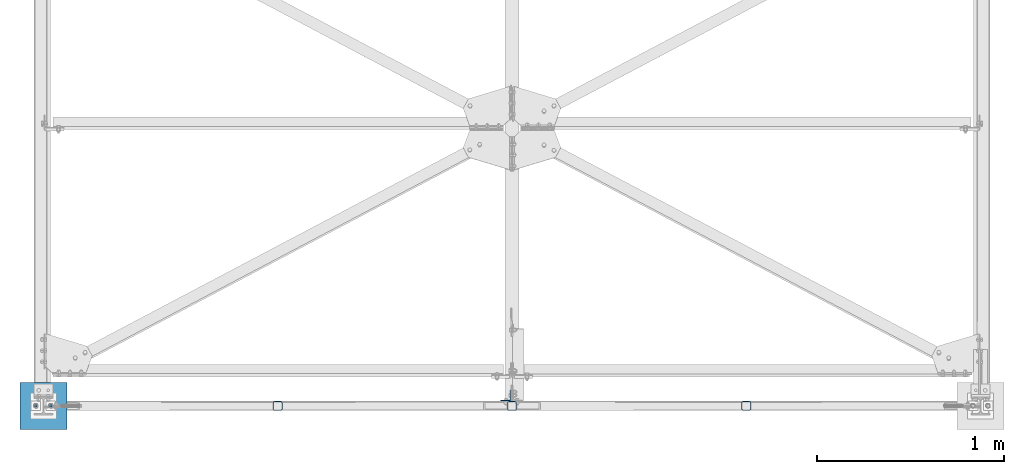
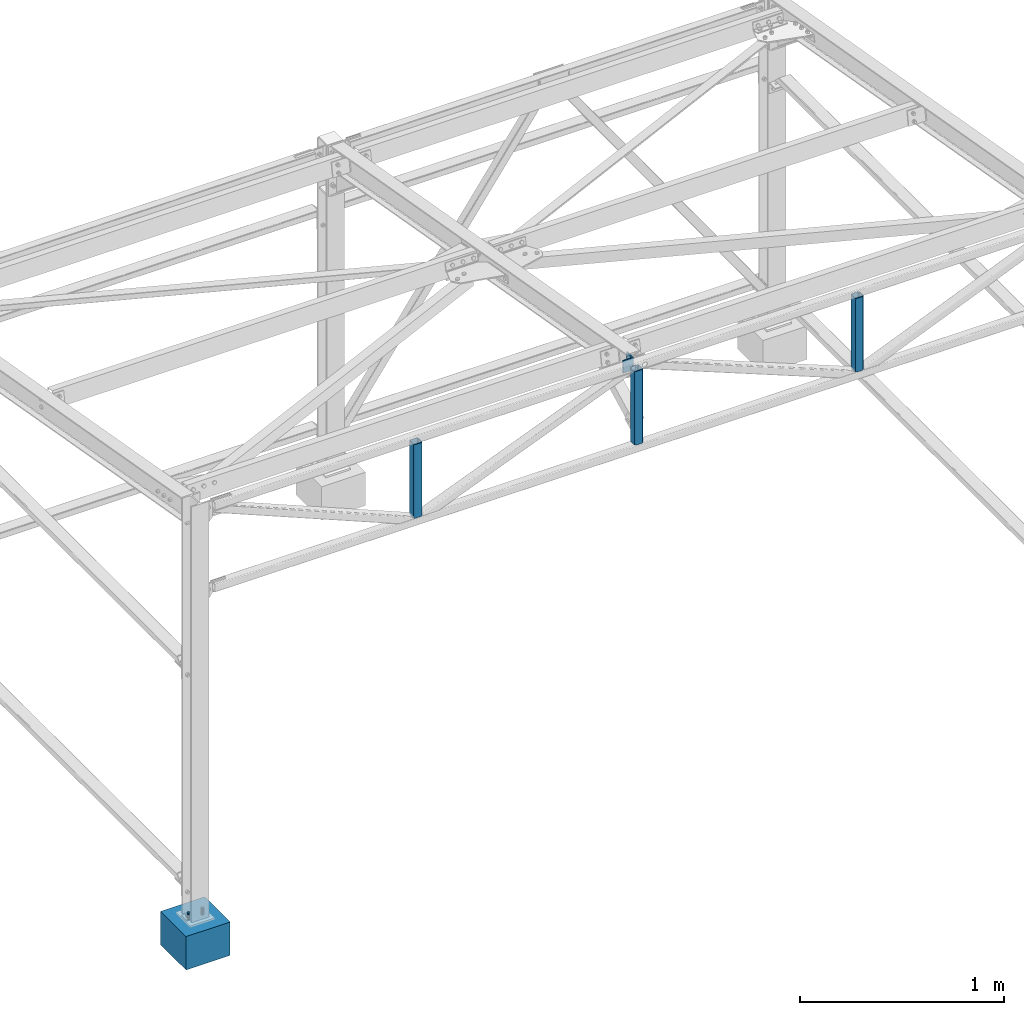
# One storey, part 2 of 28: 7 columns, 5 elements without a shape of their own.
"""IFC2X3 building model written with IfcOpenShell, lengths in millimetres."""

from ifc_helpers import new_model, si_unit, frame, origin_with_axes, origin_2d_with_axis, place, context, subcontext, project, spatial, rectangle, hollow_rectangle, circle, l_section, extrude, clip, halfspace, material, type_object, element, aggregate, save


model = new_model("IFC2X3")

# Units and contexts
model_context = context("Model", 3, precision=1e-05, world=origin_with_axes())
body_context = subcontext(model_context, "Body", "Model", "MODEL_VIEW")
ifc_project = project(units=[si_unit("LENGTHUNIT", "METRE", prefix="MILLI"), si_unit("AREAUNIT", "SQUARE_METRE"), si_unit("VOLUMEUNIT", "CUBIC_METRE"), si_unit("MASSUNIT", "GRAM", prefix="KILO"), si_unit("TIMEUNIT", "SECOND"), si_unit("PLANEANGLEUNIT", "RADIAN"), si_unit("SOLIDANGLEUNIT", "STERADIAN"), si_unit("THERMODYNAMICTEMPERATUREUNIT", "DEGREE_CELSIUS"), si_unit("LUMINOUSINTENSITYUNIT", "LUMEN")], contexts=[model_context])

# Site, building, storey
site_placement = place(None, origin_with_axes())
site = spatial("IfcSite", under=ifc_project, at=site_placement, CompositionType="ELEMENT")
building_placement = place(site_placement, origin_with_axes())
building = spatial("IfcBuilding", under=site, at=building_placement, Name="Undefined", CompositionType="ELEMENT")
storey_placement = place(building_placement, origin_with_axes())
storey = spatial("IfcBuildingStorey", under=building, at=storey_placement, Name="Undefined", CompositionType="ELEMENT", Elevation=0.0)

# Assembly, column
assembly_1_placement = place(storey_placement, origin_with_axes())
assembly_1 = element("IfcElementAssembly", 1, at=assembly_1_placement, inside=storey, Name="FA", AssemblyPlace="NOTDEFINED", PredefinedType="NOTDEFINED")
ifc_material_1 = material(Name="STEEL/S235JR")
column_type_1 = type_object("IfcColumnType", PredefinedType="NOTDEFINED")
column_1_placement = place(assembly_1_placement, frame((2467.65, 55.0, 2585.99989966715), z_axis=(0.0, 0.0, 1.0), x_axis=(0.0, 1.0, 0.0)))
column_1 = element("IfcColumn", 2, at=column_1_placement, type_object=column_type_1, material=ifc_material_1, Name="FA", context=body_context, shape_type="SweptSolid", body=[
    extrude(l_section(Depth=60.0, Width=60.0, Thickness=6.0, FilletRadius=9.0, at=origin_2d_with_axis()), frame((0.0, 0.0, 75.0), z_axis=(0.0, 0.0, -1.0), x_axis=(0.0, 1.0, 0.0)), (0.0, 0.0, 1.0), 75.0),
])
aggregate(assembly_1, [column_1])

assembly_2_placement = place(storey_placement, origin_with_axes())
assembly_2 = element("IfcElementAssembly", 3, at=assembly_2_placement, inside=storey, AssemblyPlace="NOTDEFINED", PredefinedType="NOTDEFINED")
column_type_2 = type_object("IfcColumnType", Name="D14", PredefinedType="NOTDEFINED")
column_2_placement = place(assembly_2_placement, frame((-40.0000000003815, 9.91491333479644e-10, 239.999895901477), z_axis=(0.0, 0.0, -1.0), x_axis=(0.0, -1.0, 0.0)))
column_2 = element("IfcColumn", 4, at=column_2_placement, type_object=column_type_2, material=ifc_material_1, context=body_context, shape_type="SweptSolid", body=[
    extrude(circle(Radius=7.0, at=origin_2d_with_axis()), frame((0.0, 0.0, 200.0), z_axis=(0.0, 0.0, -1.0), x_axis=(0.0, 1.0, 0.0)), (0.0, 0.0, 1.0), 200.0),
])
aggregate(assembly_2, [column_2])

assembly_3_placement = place(storey_placement, origin_with_axes())
assembly_3 = element("IfcElementAssembly", 5, at=assembly_3_placement, inside=storey, AssemblyPlace="NOTDEFINED", PredefinedType="NOTDEFINED")
column_3_placement = place(assembly_3_placement, frame((39.9999999996185, 9.91491333479644e-10, 239.999895901477), z_axis=(0.0, 0.0, -1.0), x_axis=(0.0, 1.0, 0.0)))
column_3 = element("IfcColumn", 6, at=column_3_placement, type_object=column_type_2, material=ifc_material_1, context=body_context, shape_type="SweptSolid", body=[
    extrude(circle(Radius=7.0, at=origin_2d_with_axis()), frame((0.0, 0.0, 200.0), z_axis=(0.0, 0.0, -1.0), x_axis=(0.0, 1.0, 0.0)), (0.0, 0.0, 1.0), 200.0),
])
aggregate(assembly_3, [column_3])

assembly_4_placement = place(storey_placement, origin_with_axes())
assembly_4 = element("IfcElementAssembly", 7, at=assembly_4_placement, inside=storey, Name="POTEAU", AssemblyPlace="NOTDEFINED", PredefinedType="NOTDEFINED")
ifc_material_2 = material(Name="CONCRETE/C25/30")
column_type_3 = type_object("IfcColumnType", PredefinedType="NOTDEFINED")
column_4_placement = place(assembly_4_placement, frame((0.0, 0.0, 0.0), z_axis=(0.0, 0.0, 1.0), x_axis=(0.0, 1.0, 0.0)))
column_4 = element("IfcColumn", 8, at=column_4_placement, type_object=column_type_3, material=ifc_material_2, Name="POTEAU", context=body_context, shape_type="SweptSolid", body=[
    extrude(rectangle(XDim=250.0, YDim=250.0, at=origin_2d_with_axis()), frame((0.0, 0.0, 200.0), z_axis=(0.0, 0.0, -1.0), x_axis=(0.0, 1.0, 0.0)), (0.0, 0.0, 1.0), 200.0),
])
aggregate(assembly_4, [column_4])

# Assembly, columns
assembly_5_placement = place(storey_placement, origin_with_axes())
assembly_5 = element("IfcElementAssembly", 9, at=assembly_5_placement, inside=storey, Name="TREILLIS", AssemblyPlace="NOTDEFINED", PredefinedType="NOTDEFINED")
column_type_4 = type_object("IfcColumnType", PredefinedType="NOTDEFINED")
column_5_placement = place(assembly_5_placement, frame((3749.8222443927, -0.000311427450608193, 2145.07998469004), z_axis=(0.00013401400000248, 0.0, 0.999999991020124), x_axis=(-0.999999991020124, 0.0, 0.00013401400000248)))
column_5 = element("IfcColumn", 10, at=column_5_placement, type_object=column_type_4, material=ifc_material_1, Name="TREILLIS", context=body_context, shape_type="Clipping", body=[
    clip(clip(extrude(hollow_rectangle(XDim=50.0, YDim=50.0, WallThickness=3.2, InnerFilletRadius=6.4, OuterFilletRadius=9.6, at=origin_2d_with_axis()), frame((0.0, 5.42101086242752e-20, 500.054416735034), z_axis=(0.0, 0.0, -1.0), x_axis=(0.0, 1.0, 0.0)), (0.0, 0.0, 1.0), 500.05), halfspace(frame((-25.1811164088804, 24.9999956499896, 465.923293783182), z_axis=(0.00013401400000248, 0.0, 0.999999991020124), x_axis=(0.999999991020124, 0.0, -0.00013401400000248)), False)), halfspace(frame((-25.1811056758606, -25.0000043500104, 25.0033748447186), z_axis=(-0.00013401400000248, 0.0, -0.999999991020124), x_axis=(0.999999991020124, 0.0, -0.00013401400000248)), False)),
])
column_6_placement = place(assembly_5_placement, frame((1249.82224620682, -0.000311427450608193, 2170.13439693474), z_axis=(-0.000141099000006234, 0.0, 0.999999990045536), x_axis=(0.999999990045536, 0.0, 0.000141099000006307)))
column_6 = element("IfcColumn", 11, at=column_6_placement, type_object=column_type_4, material=ifc_material_1, Name="TREILLIS", context=body_context, shape_type="Clipping", body=[
    clip(extrude(hollow_rectangle(XDim=50.0, YDim=50.0, WallThickness=3.2, InnerFilletRadius=6.4, OuterFilletRadius=9.6, at=origin_2d_with_axis()), frame((-1.28734261816147e-17, 0.0, 474.945596248077), z_axis=(0.0, 0.0, -1.0), x_axis=(0.0, 1.0, 0.0)), (0.0, 0.0, 1.0), 474.95), halfspace(frame((-24.8189056236947, 25.0003157774683, 440.869009043978), z_axis=(0.000141099000006307, 0.0, 0.999999990045536), x_axis=(0.999999990045536, 0.0, -0.000141099000006307)), False)),
])
column_7_placement = place(assembly_5_placement, frame((2499.82224502254, -0.000311427450608193, 2145.07998469004), z_axis=(-0.000134028000002006, 0.0, 0.999999991018248), x_axis=(0.999999991018248, 0.0, 0.000134028000002218)))
column_7 = element("IfcColumn", 12, at=column_7_placement, type_object=column_type_4, material=ifc_material_1, Name="TREILLIS", context=body_context, shape_type="Clipping", body=[
    clip(clip(extrude(hollow_rectangle(XDim=50.0, YDim=50.0, WallThickness=3.2, InnerFilletRadius=6.4, OuterFilletRadius=9.6, at=origin_2d_with_axis()), frame((-1.35525273798433e-17, 0.0, 500.000008255821), z_axis=(0.0, 0.0, -1.0), x_axis=(0.0, 1.0, 0.0)), (0.0, 0.0, 1.0), 500.0), halfspace(frame((-24.8188938046897, -24.9999956499896, 25.0072023322687), z_axis=(-0.00013401400000248, 0.0, -0.999999991020124), x_axis=(0.999999991020124, 0.0, -0.00013401400000248)), False)), halfspace(frame((-24.8189045269296, 25.0000043500104, 465.927210059407), z_axis=(0.00013401400000248, 0.0, 0.999999991020124), x_axis=(0.999999991020124, 0.0, -0.00013401400000248)), False)),
])
aggregate(assembly_5, [column_5, column_6, column_7])

save(model, "model.ifc")
